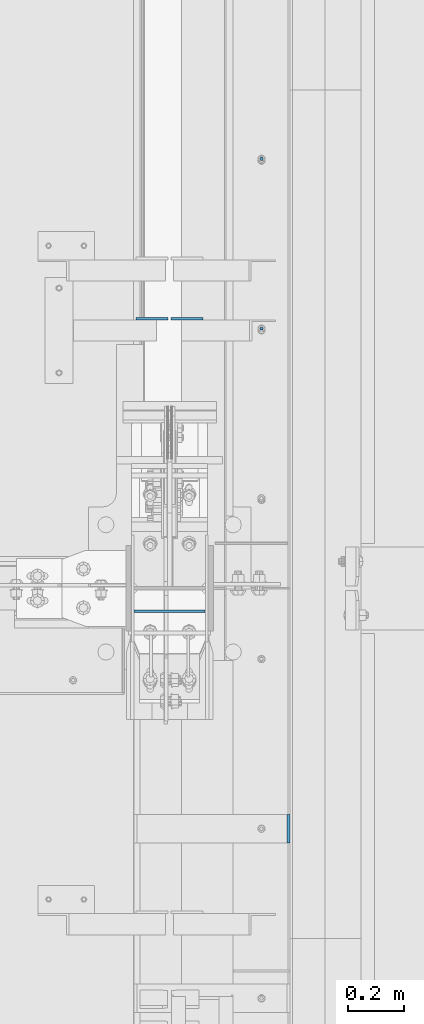
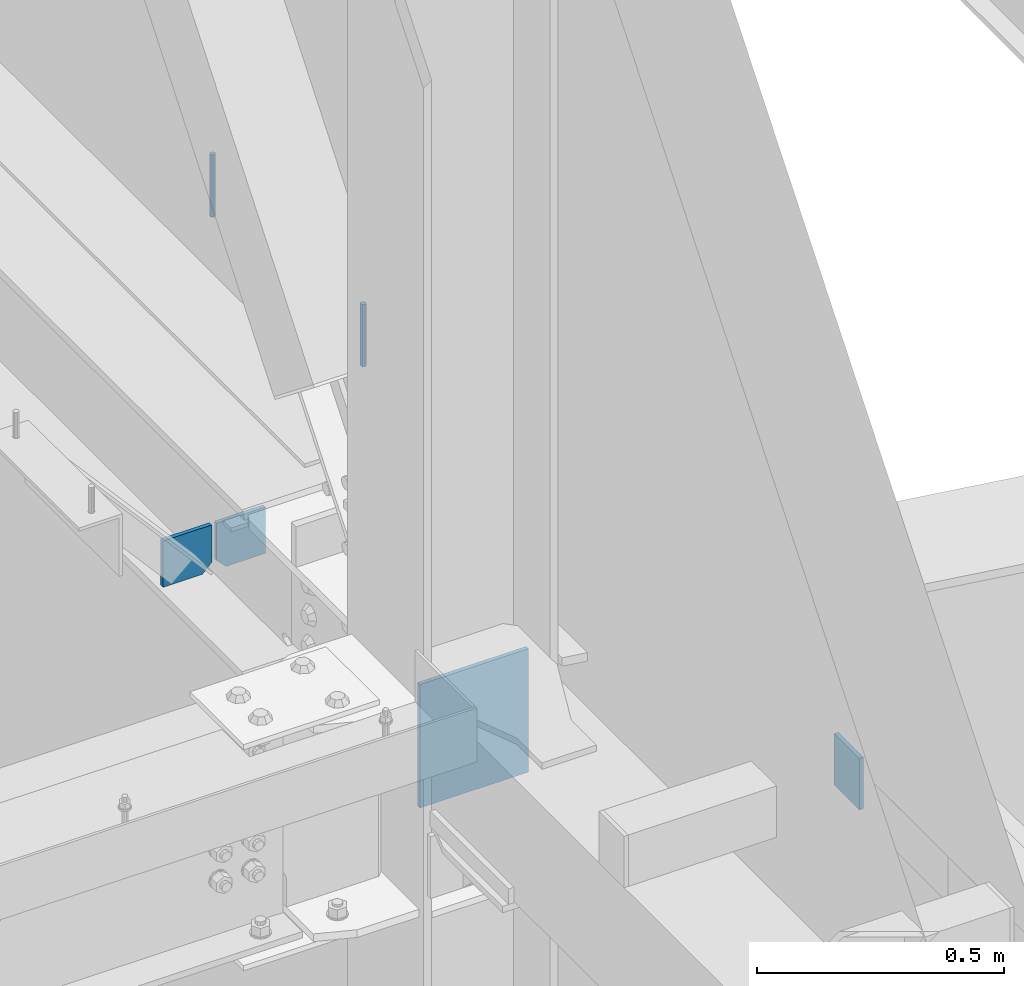
# One storey, part 470 of 1179: 6 columns, 3 elements without a shape of their own.
"""IFC2X3 building model written with IfcOpenShell, lengths in millimetres."""

from ifc_helpers import new_model, si_unit, frame, origin_with_axes, place, context, subcontext, project, spatial, faceted_brep, material, type_object, element, aggregate, save


model = new_model("IFC2X3")

# Units and contexts
model_context = context("Model", 3, precision=1e-05, world=origin_with_axes())
body_context = subcontext(model_context, "Body", "Model", "MODEL_VIEW")
ifc_project = project(units=[si_unit("LENGTHUNIT", "METRE", prefix="MILLI"), si_unit("AREAUNIT", "SQUARE_METRE"), si_unit("VOLUMEUNIT", "CUBIC_METRE"), si_unit("MASSUNIT", "GRAM", prefix="KILO"), si_unit("TIMEUNIT", "SECOND"), si_unit("PLANEANGLEUNIT", "RADIAN"), si_unit("SOLIDANGLEUNIT", "STERADIAN"), si_unit("THERMODYNAMICTEMPERATUREUNIT", "DEGREE_CELSIUS"), si_unit("LUMINOUSINTENSITYUNIT", "LUMEN")], contexts=[model_context])

# Site, building, storey
site_placement = place(None, origin_with_axes())
site = spatial("IfcSite", under=ifc_project, at=site_placement, CompositionType="ELEMENT")
building_placement = place(site_placement, origin_with_axes())
building = spatial("IfcBuilding", under=site, at=building_placement, Name="Undefined", CompositionType="ELEMENT")
storey_placement = place(building_placement, origin_with_axes())
storey = spatial("IfcBuildingStorey", under=building, at=storey_placement, Name="Undefined", CompositionType="ELEMENT", Elevation=0.0)

# Assembly, column
assembly_1_placement = place(storey_placement, origin_with_axes())
assembly_1 = element("IfcElementAssembly", 1, at=assembly_1_placement, inside=storey, Name="BEAM", AssemblyPlace="NOTDEFINED", PredefinedType="RIGID_FRAME")
ifc_material_1 = material(Name="STEEL/A36")
column_type_1 = type_object("IfcColumnType", PredefinedType="NOTDEFINED")
column_1_placement = place(assembly_1_placement, frame((24734.8375, 26187.4, 8013.69999998781), z_axis=(0.0, 1.0, 0.0), x_axis=(0.0, 0.0, 1.0)))
column_1 = element("IfcColumn", 2, at=column_1_placement, type_object=column_type_1, material=ifc_material_1, Name="PLATE", context=body_context, shape_type="Brep", body=[
    faceted_brep([(0.0, 4.76249999999982, -50.7999999999993), (0.0, 4.76249999999982, 50.7999999999993), (127.000000000371, 4.76249999928405, 50.8000000000002), (127.000000000371, 4.76249999928405, -50.8000000000002), (0.0, -4.76249999999982, 50.7999999999993), (127.0, -4.76250000000073, 50.7999999999993), (0.0, -4.76249999999982, -50.7999999999993), (127.0, -4.76250000000073, -50.7999999999993)], [[[0, 1, 2, 3]], [[1, 4, 5, 2]], [[4, 6, 7, 5]], [[6, 0, 3, 7]], [[5, 7, 3, 2]], [[6, 4, 1, 0]]]),
])
aggregate(assembly_1, [column_1])

# Assembly, columns
assembly_2_placement = place(storey_placement, origin_with_axes())
assembly_2 = element("IfcElementAssembly", 3, at=assembly_2_placement, inside=storey, Name="BEAM", AssemblyPlace="NOTDEFINED", PredefinedType="RIGID_FRAME")
column_type_2 = type_object("IfcColumnType", PredefinedType="NOTDEFINED")
column_2_placement = place(assembly_2_placement, frame((24245.09375, 28020.3463232685, 7613.65), z_axis=(1.0, 0.0, 0.0), x_axis=(0.0, 0.0, 1.0)))
column_2 = element("IfcColumn", 4, at=column_2_placement, type_object=column_type_2, material=ifc_material_1, Name="PLATE", context=body_context, shape_type="Brep", body=[
    faceted_brep([(22.2250000000004, 4.76250000000073, 57.1500000000015), (0.0, 4.76250000000073, 34.9249999999993), (0.0, -4.76250000000073, 34.9249999999993), (22.2250000000004, -4.76250000000073, 57.1500000000015), (114.300000000001, 4.76250000000073, 57.1500000000015), (114.300000000001, 4.76250000000073, -57.1500000000015), (0.0, 4.76250000000073, -57.1500000000015), (114.300000000001, -4.76250000000073, 57.1500000000015), (0.0, -4.76250000000073, -57.1500000000015), (114.300000000001, -4.76250000000073, -57.1500000000015)], [[[0, 1, 2, 3]], [[4, 5, 6, 1, 0]], [[7, 4, 0, 3]], [[8, 9, 7, 3, 2]], [[8, 6, 5, 9]], [[7, 9, 5, 4]], [[6, 8, 2, 1]]]),
])
column_3_placement = place(assembly_2_placement, frame((24370.50625, 28020.3463232685, 7613.65), z_axis=(-1.0, 0.0, 0.0), x_axis=(0.0, 0.0, 1.0)))
column_3 = element("IfcColumn", 5, at=column_3_placement, type_object=column_type_2, material=ifc_material_1, Name="PLATE", context=body_context, shape_type="Brep", body=[
    faceted_brep([(22.2250000000004, 4.76250000000073, 57.1500000000015), (0.0, 4.76250000000073, 34.9249999999993), (0.0, -4.76250000000073, 34.9249999999993), (22.2250000000004, -4.76250000000073, 57.1500000000015), (114.300000000001, 4.76250000000073, 57.1500000000015), (114.300000000001, 4.76250000000073, -57.1500000000015), (0.0, 4.76250000000073, -57.1500000000015), (114.300000000001, -4.76250000000073, 57.1500000000015), (0.0, -4.76250000000073, -57.1500000000015), (114.300000000001, -4.76250000000073, -57.1500000000015)], [[[0, 1, 2, 3]], [[4, 5, 6, 1, 0]], [[7, 4, 0, 3]], [[8, 9, 7, 3, 2]], [[8, 6, 5, 9]], [[7, 9, 5, 4]], [[6, 8, 2, 1]]]),
])
ifc_material_2 = material(Name="STEEL/A307")
column_type_3 = type_object("IfcColumnType", PredefinedType="NOTDEFINED")
column_4_placement = place(assembly_2_placement, frame((24638.0000051215, 28594.0500001664, 8023.22499553788), z_axis=(0.0, 1.0, 0.0), x_axis=(0.0, 0.0, 1.0)))
column_4 = element("IfcColumn", 6, at=column_4_placement, type_object=column_type_3, material=ifc_material_2, Name="THREADED ROD", context=body_context, shape_type="Brep", body=[
    faceted_brep([(0.0, -6.34999999999854, 0.0), (0.0, -4.49012806053361, -4.49012806053452), (153.987504462122, -4.49012806053361, -4.49012806053361), (153.987504462122, -6.34999999999854, 0.0), (0.0, 0.0, -6.34999999999991), (153.987504462122, 0.0, -6.34999999999854), (0.0, 4.49012806053361, -4.49012806053452), (153.987504462122, 4.49012806053361, -4.49012806053361), (0.0, 6.34999999999854, 0.0), (153.987504462122, 6.34999999999854, 0.0), (0.0, 4.49012806053361, 4.49012806053452), (153.987504462122, 4.49012806053361, 4.49012806053361), (0.0, 0.0, 6.34999999999991), (153.987504462122, 0.0, 6.34999999999854), (0.0, -4.49012806053361, 4.49012806053452), (153.987504462122, -4.49012806053361, 4.49012806053361)], [[[0, 1, 2, 3]], [[1, 4, 5, 2]], [[4, 6, 7, 5]], [[6, 8, 9, 7]], [[8, 10, 11, 9]], [[10, 12, 13, 11]], [[12, 14, 15, 13]], [[14, 0, 3, 15]], [[5, 7, 9, 11, 13, 15, 3, 2]], [[14, 12, 10, 8, 6, 4, 1, 0]]]),
])
column_5_placement = place(assembly_2_placement, frame((24638.0000051215, 27984.4500001664, 8023.22499553788), z_axis=(0.0, 1.0, 0.0), x_axis=(0.0, 0.0, 1.0)))
column_5 = element("IfcColumn", 7, at=column_5_placement, type_object=column_type_3, material=ifc_material_2, Name="THREADED ROD", context=body_context, shape_type="Brep", body=[
    faceted_brep([(0.0, -6.34999999999854, 0.0), (0.0, -4.49012806053361, -4.49012806053452), (153.987504462122, -4.49012806053361, -4.49012806053361), (153.987504462122, -6.34999999999854, 0.0), (0.0, 0.0, -6.34999999999991), (153.987504462122, 0.0, -6.34999999999854), (0.0, 4.49012806053361, -4.49012806053452), (153.987504462122, 4.49012806053361, -4.49012806053361), (0.0, 6.34999999999854, 0.0), (153.987504462122, 6.34999999999854, 0.0), (0.0, 4.49012806053361, 4.49012806053452), (153.987504462122, 4.49012806053361, 4.49012806053361), (0.0, 0.0, 6.34999999999991), (153.987504462122, 0.0, 6.34999999999854), (0.0, -4.49012806053361, 4.49012806053452), (153.987504462122, -4.49012806053361, 4.49012806053361)], [[[0, 1, 2, 3]], [[1, 4, 5, 2]], [[4, 6, 7, 5]], [[6, 8, 9, 7]], [[8, 10, 11, 9]], [[10, 12, 13, 11]], [[12, 14, 15, 13]], [[14, 0, 3, 15]], [[5, 7, 9, 11, 13, 15, 3, 2]], [[14, 12, 10, 8, 6, 4, 1, 0]]]),
])
aggregate(assembly_2, [column_2, column_3, column_4, column_5])

# Assembly, column
assembly_3_placement = place(storey_placement, origin_with_axes())
assembly_3 = element("IfcElementAssembly", 8, at=assembly_3_placement, inside=storey, Name="BEAM", AssemblyPlace="NOTDEFINED", PredefinedType="RIGID_FRAME")
column_type_4 = type_object("IfcColumnType", PredefinedType="NOTDEFINED")
column_6_placement = place(assembly_3_placement, frame((24307.8, 26968.45, 7708.90000000912), z_axis=(-1.0, 0.0, 0.0), x_axis=(0.0, 0.0, 1.0)))
column_6 = element("IfcColumn", 9, at=column_6_placement, type_object=column_type_4, material=ifc_material_1, Name="PLATE", context=body_context, shape_type="Brep", body=[
    faceted_brep([(0.0, 4.76249999999982, -127.0), (0.0, 4.76249999999709, 127.0), (304.799999999999, 4.76249999999982, 127.0), (304.799999999999, 4.76249999999982, -127.0), (0.0, -4.76249999999709, 127.0), (304.799999999999, -4.76249999999982, 127.0), (0.0, -4.76249999999982, -127.0), (304.799999999999, -4.76249999999982, -127.0)], [[[0, 1, 2, 3]], [[1, 4, 5, 2]], [[4, 6, 7, 5]], [[6, 0, 3, 7]], [[5, 7, 3, 2]], [[6, 4, 1, 0]]]),
])
aggregate(assembly_3, [column_6])

save(model, "model.ifc")
